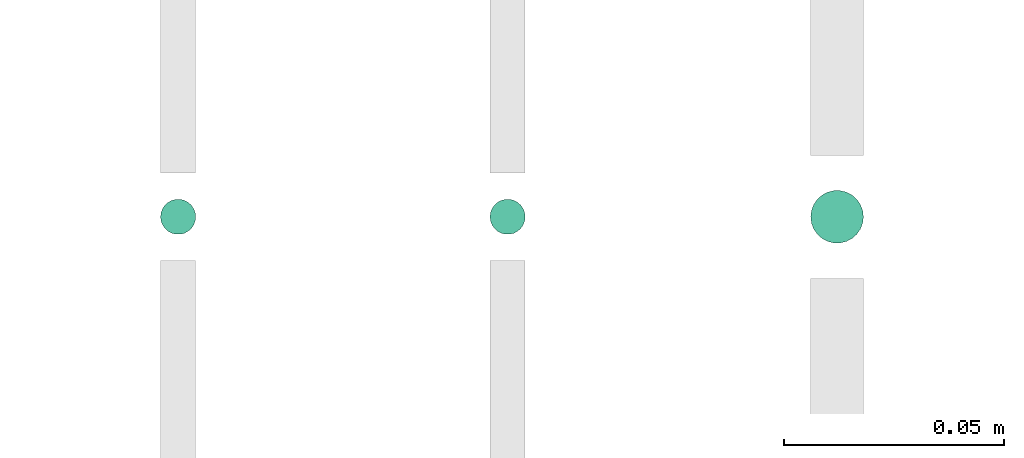
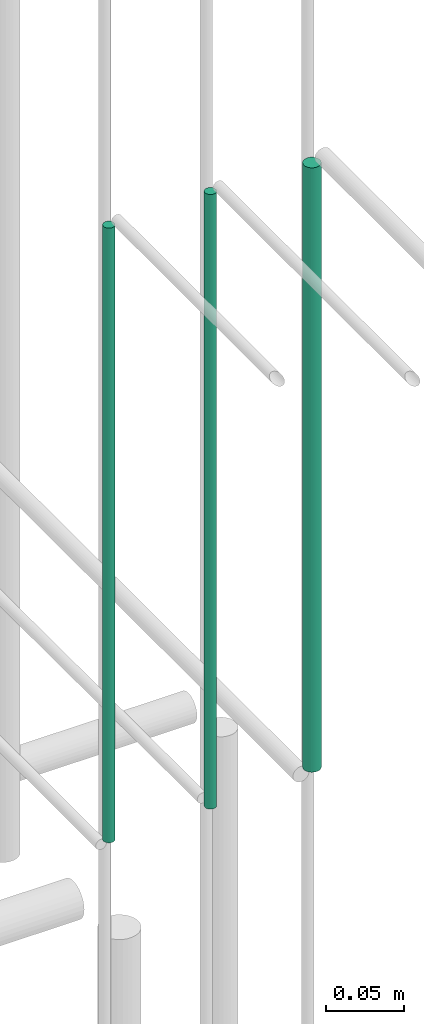
# One storey, part 227 of 331: 3 flow segments.
"""IFC2X3 building model written with IfcOpenShell, lengths in millimetres."""

from ifc_helpers import new_model, entity, si_unit, converted_unit, derived_unit, direction, frame, origin, origin_2d_with_axis, place, context, subcontext, project, spatial, circle, extrude, type_object, element, save


model = new_model("IFC2X3")

# Units and contexts
model_context = context("Model", 3, precision=0.01, world=origin(), true_north=direction((6.12303176911189e-17, 1.0)))
body_context = subcontext(model_context, "Body", "Model", "MODEL_VIEW")
ifc_project = project(units=[si_unit("LENGTHUNIT", "METRE", prefix="MILLI"), si_unit("AREAUNIT", "SQUARE_METRE"), si_unit("VOLUMEUNIT", "CUBIC_METRE"), converted_unit("PLANEANGLEUNIT", "DEGREE", entity("IfcRatioMeasure", 0.0174532925199433), si_unit("PLANEANGLEUNIT", "RADIAN"), dimensions=[0, 0, 0, 0, 0, 0, 0]), si_unit("MASSUNIT", "GRAM", prefix="KILO"), derived_unit("MASSDENSITYUNIT", [(si_unit("MASSUNIT", "GRAM", prefix="KILO"), 1), (si_unit("LENGTHUNIT", "METRE"), -3)]), derived_unit("MOMENTOFINERTIAUNIT", [(si_unit("LENGTHUNIT", "METRE"), 4)]), si_unit("TIMEUNIT", "SECOND"), si_unit("FREQUENCYUNIT", "HERTZ"), si_unit("THERMODYNAMICTEMPERATUREUNIT", "DEGREE_CELSIUS"), derived_unit("THERMALTRANSMITTANCEUNIT", [(si_unit("MASSUNIT", "GRAM", prefix="KILO"), 1), (si_unit("THERMODYNAMICTEMPERATUREUNIT", "KELVIN"), -1), (si_unit("TIMEUNIT", "SECOND"), -3)]), derived_unit("VOLUMETRICFLOWRATEUNIT", [(si_unit("LENGTHUNIT", "METRE"), 3), (si_unit("TIMEUNIT", "SECOND"), -1)]), derived_unit("MASSFLOWRATEUNIT", [(si_unit("MASSUNIT", "GRAM", prefix="KILO"), 1), (si_unit("TIMEUNIT", "SECOND"), -1)]), derived_unit("ROTATIONALFREQUENCYUNIT", [(si_unit("TIMEUNIT", "SECOND"), -1)]), si_unit("ELECTRICCURRENTUNIT", "AMPERE"), si_unit("ELECTRICVOLTAGEUNIT", "VOLT"), si_unit("POWERUNIT", "WATT"), si_unit("FORCEUNIT", "NEWTON", prefix="KILO"), si_unit("ILLUMINANCEUNIT", "LUX"), si_unit("LUMINOUSFLUXUNIT", "LUMEN"), si_unit("LUMINOUSINTENSITYUNIT", "CANDELA"), derived_unit("USERDEFINED", [(si_unit("MASSUNIT", "GRAM", prefix="KILO"), -1), (si_unit("LENGTHUNIT", "METRE"), -2), (si_unit("TIMEUNIT", "SECOND"), 3), (si_unit("LUMINOUSFLUXUNIT", "LUMEN"), 1)]), derived_unit("LINEARVELOCITYUNIT", [(si_unit("LENGTHUNIT", "METRE"), 1), (si_unit("TIMEUNIT", "SECOND"), -1)]), si_unit("PRESSUREUNIT", "PASCAL"), derived_unit("USERDEFINED", [(si_unit("LENGTHUNIT", "METRE"), -2), (si_unit("MASSUNIT", "GRAM", prefix="KILO"), 1), (si_unit("TIMEUNIT", "SECOND"), -2)]), derived_unit("LINEARFORCEUNIT", [(si_unit("MASSUNIT", "GRAM", prefix="KILO"), 1), (si_unit("LENGTHUNIT", "METRE"), 1), (si_unit("TIMEUNIT", "SECOND"), -2), (si_unit("LENGTHUNIT", "METRE"), -1)]), derived_unit("PLANARFORCEUNIT", [(si_unit("MASSUNIT", "GRAM", prefix="KILO"), 1), (si_unit("LENGTHUNIT", "METRE"), 1), (si_unit("TIMEUNIT", "SECOND"), -2), (si_unit("LENGTHUNIT", "METRE"), -2)])], contexts=[model_context])

# Site, building, storey
site_placement = place(None, frame((0.0, -0.00077364408347762, 0.0)))
site = spatial("IfcSite", under=ifc_project, at=site_placement, CompositionType="ELEMENT")
building_placement = place(site_placement, origin())
building = spatial("IfcBuilding", under=site, at=building_placement, CompositionType="ELEMENT")
storey_placement = place(building_placement, origin())
storey = spatial("IfcBuildingStorey", under=building, at=storey_placement, CompositionType="ELEMENT", Elevation=0.0)

# Flow segments
pipe_segment_type = type_object("IfcPipeSegmentType", PredefinedType="NOTDEFINED")
flow_segment_1_placement = place(building_placement, frame((65227.5100168243, 5192.40472776408, 6764.0)))
element("IfcFlowSegment", 1, at=flow_segment_1_placement, inside=storey, type_object=pipe_segment_type, context=body_context, shape_type="SweptSolid", body=[
    extrude(circle(Radius=6.0, at=origin_2d_with_axis()), frame((7.59527223591454, 7.59527223591562, 0.0), z_axis=(0.0, 0.0, 1.0), x_axis=(-1.0, 0.0, 0.0)), (0.0, 0.0, 1.0), 472.000000000008),
])
flow_segment_2_placement = place(building_placement, frame((65154.5100168243, 5194.40472776408, 6760.0)))
element("IfcFlowSegment", 2, at=flow_segment_2_placement, inside=storey, type_object=pipe_segment_type, context=body_context, shape_type="SweptSolid", body=[
    extrude(circle(Radius=4.0, at=origin_2d_with_axis()), frame((5.59527223591499, 5.59527223591607, 0.0), z_axis=(0.0, 0.0, 1.0), x_axis=(-1.0, 0.0, 0.0)), (0.0, 0.0, 1.0), 480.000000000009),
])
flow_segment_3_placement = place(building_placement, frame((65079.5100168242, 5194.40537015912, 6760.0)))
element("IfcFlowSegment", 3, at=flow_segment_3_placement, inside=storey, type_object=pipe_segment_type, context=body_context, shape_type="SweptSolid", body=[
    extrude(circle(Radius=4.0, at=origin_2d_with_axis()), frame((5.59527223591499, 5.59527223591607, 0.0), z_axis=(0.0, 0.0, 1.0), x_axis=(-1.0, 0.0, 0.0)), (0.0, 0.0, 1.0), 480.0),
])

save(model, "model.ifc")
